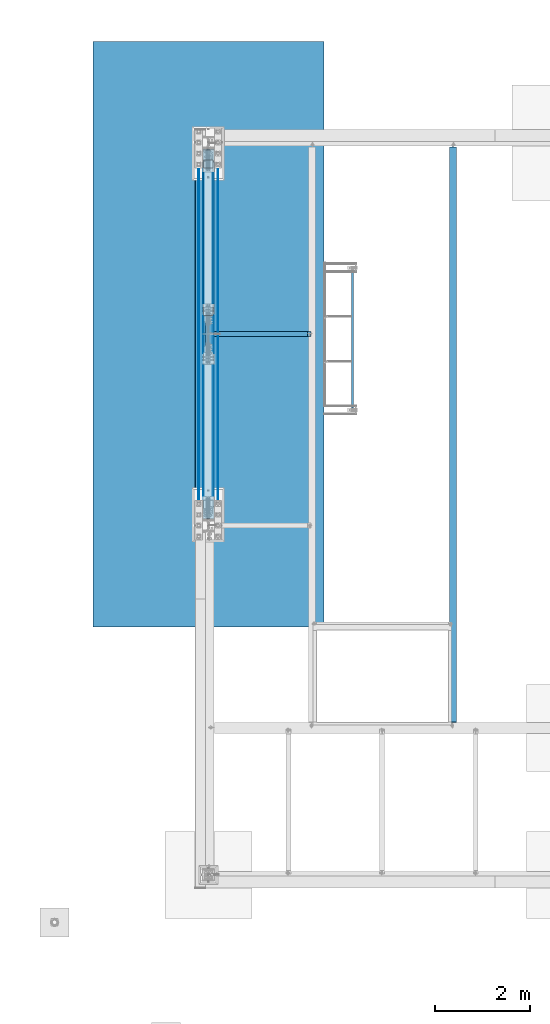
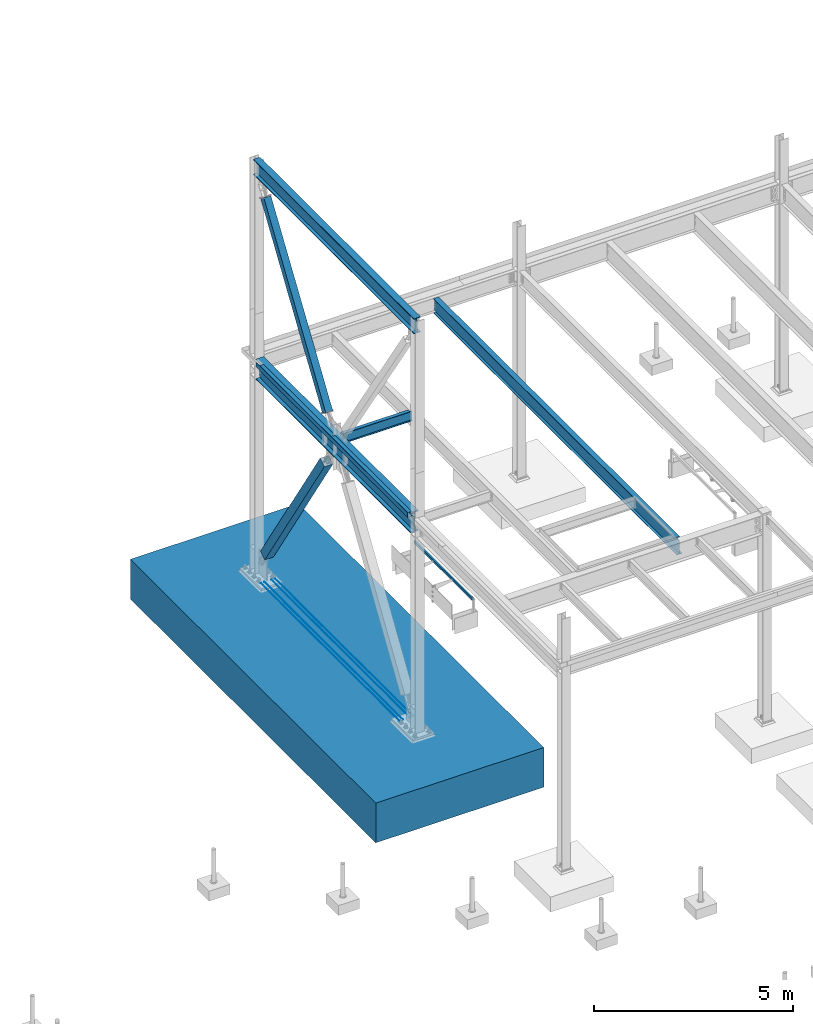
# One storey, part 1865 of 3843: 11 beams, 2 members, 12 elements without a shape of their own.
"""IFC2X3 building model written with IfcOpenShell, lengths in millimetres."""

import ifcopenshell
import ifcopenshell.guid

model = None  # the IFC model being written
_history = None  # IfcOwnerHistory: only IFC2X3 demands one
_inside = {}  # id of a spatial element -> (the spatial element, [elements in it])
_under = {}  # id of a project, library or spatial element -> (it, [spatial elements below it])
_declared = {}  # id of a project -> (the project, [libraries it declares])
_typed = {}  # id of a type object -> (the type object, [elements of that type])
_made_of = {}  # id of a material, layer set ... -> (it, [elements and type objects made of it])


def new_model(schema):
    """Start an empty IFC model of exactly this schema.

    Asked for "IFC4X3", IfcOpenShell would pick the latest addendum, in which some entities
    have other attributes; the version numbers below select the first issue.
    IFC2X3 requires an IfcOwnerHistory on every rooted entity: one is made here for all.
    """
    global model, _history
    if schema == "IFC4X3":
        model = ifcopenshell.file(schema_version=(4, 3, 0, 0))
    else:
        model = ifcopenshell.file(schema=schema)
    _inside.clear()
    _under.clear()
    _declared.clear()
    _typed.clear()
    _made_of.clear()
    _history = None
    if model.schema == "IFC2X3":
        org = make("IfcOrganization", Name="unknown")
        user = make(
            "IfcPersonAndOrganization",
            ThePerson=make("IfcPerson", FamilyName="unknown"),
            TheOrganization=org,
        )
        app = make(
            "IfcApplication",
            ApplicationDeveloper=org,
            Version="unknown",
            ApplicationFullName="unknown",
            ApplicationIdentifier="unknown",
        )
        _history = make(
            "IfcOwnerHistory",
            OwningUser=user,
            OwningApplication=app,
            ChangeAction="ADDED",
            CreationDate=0,
        )
    return model


def make(cls, **values):
    """One entity of the class cls with the attributes given. An attribute that is None is left unset."""
    return model.create_entity(
        cls, **{name: value for name, value in values.items() if value is not None}
    )


def rooted(cls, **values):
    """An entity with a GlobalId (a new one), such as an element, a storey or a relation."""
    return make(cls, GlobalId=ifcopenshell.guid.new(), OwnerHistory=_history, **values)


def si_unit(unit_type, name, prefix=None):
    """IfcSIUnit, for example si_unit("LENGTHUNIT", "METRE", prefix="MILLI")."""
    return make("IfcSIUnit", UnitType=unit_type, Prefix=prefix, Name=name)


def assignment(units):
    """IfcUnitAssignment: the units of a project."""
    return None if units is None else make("IfcUnitAssignment", Units=units)


def point(xyz):
    """IfcCartesianPoint."""
    return None if xyz is None else make("IfcCartesianPoint", Coordinates=xyz)


def direction(xyz):
    """IfcDirection."""
    return None if xyz is None else make("IfcDirection", DirectionRatios=xyz)


def frame(location, z_axis=None, x_axis=None):
    """IfcAxis2Placement3D, a coordinate frame: its origin and axes. An axis left out is left unset."""
    return make(
        "IfcAxis2Placement3D",
        Location=point(location),
        Axis=direction(z_axis),
        RefDirection=direction(x_axis),
    )


def origin_with_axes():
    """The frame at (0, 0, 0) with the z axis (0, 0, 1) and the x axis (1, 0, 0) written out."""
    return frame((0.0, 0.0, 0.0), z_axis=(0.0, 0.0, 1.0), x_axis=(1.0, 0.0, 0.0))


def place(relative_to, where):
    """IfcLocalPlacement: puts the frame where relative to a parent placement (None: the world)."""
    return make(
        "IfcLocalPlacement", PlacementRelTo=relative_to, RelativePlacement=where
    )


def context(
    kind, dimensions, precision=None, world=None, true_north=None, identifier=None
):
    """IfcGeometricRepresentationContext, for example the 3D "Model" context."""
    return make(
        "IfcGeometricRepresentationContext",
        ContextIdentifier=identifier,
        ContextType=kind,
        CoordinateSpaceDimension=dimensions,
        Precision=precision,
        WorldCoordinateSystem=world,
        TrueNorth=true_north,
    )


def subcontext(parent, identifier, kind, view, scale=None):
    """IfcGeometricRepresentationSubContext, for example "Body" below "Model"."""
    return make(
        "IfcGeometricRepresentationSubContext",
        ContextIdentifier=identifier,
        ContextType=kind,
        ParentContext=parent,
        TargetScale=scale,
        TargetView=view,
    )


def project(units=None, contexts=None):
    """IfcProject with its units and contexts."""
    return rooted(
        "IfcProject",
        Name="project",
        RepresentationContexts=contexts,
        UnitsInContext=assignment(units),
    )


def spatial(cls, under=None, at=None, **own):
    """A site, building, storey or space (cls), placed at a placement, below another one or the project."""
    s = rooted(cls, ObjectPlacement=at, **own)
    if under is not None:
        _under.setdefault(under.id(), (under, []))[1].append(s)
    return s


def faces_of(points, faces, orient=None, outer=None):
    """IfcFace entities. A face is a list of loops; a loop is a list of indices into points, from 0.

    orient and outer hold one flag for each loop. By default every Orientation is true, the
    first loop of a face is its IfcFaceOuterBound and the others are IfcFaceBound.
    """
    made = []
    for i, loops in enumerate(faces):
        bounds = []
        for j, loop in enumerate(loops):
            is_outer = j == 0 if outer is None else outer[i][j]
            bounds.append(
                make(
                    "IfcFaceOuterBound" if is_outer else "IfcFaceBound",
                    Bound=make("IfcPolyLoop", Polygon=[points[k] for k in loop]),
                    Orientation=True if orient is None else orient[i][j],
                )
            )
        made.append(make("IfcFace", Bounds=bounds))
    return made


def faceted_brep(points, faces, orient=None, outer=None, voids=None):
    """IfcFacetedBrep: a solid bounded by flat faces; with voids (closed shells), ...WithVoids."""
    shared = [point(p) for p in points]
    hull = make("IfcClosedShell", CfsFaces=faces_of(shared, faces, orient, outer))
    if voids is None:
        return make("IfcFacetedBrep", Outer=hull)
    return make(
        "IfcFacetedBrepWithVoids",
        Outer=hull,
        Voids=[
            make(cls, CfsFaces=faces_of(shared, fs, o, b)) for cls, fs, o, b in voids
        ],
    )


def shape(context_of_items, identifier, shape_type, items):
    """IfcShapeRepresentation: the items that make up one representation, for example the "Body"."""
    return make(
        "IfcShapeRepresentation",
        ContextOfItems=context_of_items,
        RepresentationIdentifier=identifier,
        RepresentationType=shape_type,
        Items=items,
    )


def material(Name=None, Category=None):
    """IfcMaterial."""
    return make("IfcMaterial", Name=Name, Category=Category)


def made_of(thing, what):
    """Note that an element or type object is made of a material, layer set ...; save() writes the relation."""
    if what is not None:
        _made_of.setdefault(what.id(), (what, []))[1].append(thing)
    return thing


def type_object(cls, material=None, **own):
    """A type object (cls), such as IfcWallType, which elements share."""
    return made_of(rooted(cls, **own), material)


def element(
    cls,
    number,
    at=None,
    inside=None,
    cuts=None,
    type_object=None,
    material=None,
    context=None,
    identifier="Body",
    shape_type=None,
    held_by="IfcProductDefinitionShape",
    body=None,
    shapes=None,
    **own,
):
    """One element of the class cls, such as IfcWall. Its Tag is "e" and its number.

    at: its placement. inside: the storey or other place that contains it. cuts: it is an
    opening in that element (IfcRelVoidsElement). A single representation is given by context,
    identifier, shape_type and body (its items); several are given by shapes. held_by: the class
    of the entity that holds the representations. save() writes the other relations.
    """
    e = rooted(cls, Tag="e%d" % number, ObjectPlacement=at, **own)
    if body is not None:
        shapes = [shape(context, identifier, shape_type, body)]
    if shapes is not None:
        e.Representation = make(held_by, Representations=shapes)
    if inside is not None:
        _inside.setdefault(inside.id(), (inside, []))[1].append(e)
    if cuts is not None:
        rooted(
            "IfcRelVoidsElement", RelatingBuildingElement=cuts, RelatedOpeningElement=e
        )
    if type_object is not None:
        _typed.setdefault(type_object.id(), (type_object, []))[1].append(e)
    return made_of(e, material)


def aggregate(whole, parts):
    """IfcRelAggregates: a whole, such as a stair, and the parts it consists of."""
    return rooted("IfcRelAggregates", RelatingObject=whole, RelatedObjects=parts)


def save(model, path):
    """Write the relations noted so far, then the file.

    IfcRelAggregates (storeys below a building ...), IfcRelContainedInSpatialStructure (elements
    in a storey), IfcRelDefinesByType, IfcRelAssociatesMaterial and IfcRelDeclares: one each for
    every whole, place, type object, material and project.
    """
    for whole, parts in _under.values():
        aggregate(whole, parts)
    for where, things in _inside.values():
        rooted(
            "IfcRelContainedInSpatialStructure",
            RelatedElements=things,
            RelatingStructure=where,
        )
    for kind, things in _typed.values():
        rooted("IfcRelDefinesByType", RelatedObjects=things, RelatingType=kind)
    for what, things in _made_of.values():
        rooted("IfcRelAssociatesMaterial", RelatedObjects=things, RelatingMaterial=what)
    for by, libraries in _declared.values():
        rooted("IfcRelDeclares", RelatingContext=by, RelatedDefinitions=libraries)
    model.write(path)


model = new_model("IFC2X3")

# Units and contexts
model_context = context("Model", 3, precision=1e-05, world=origin_with_axes())
body_context = subcontext(model_context, "Body", "Model", "MODEL_VIEW")
ifc_project = project(units=[si_unit("LENGTHUNIT", "METRE", prefix="MILLI"), si_unit("AREAUNIT", "SQUARE_METRE"), si_unit("VOLUMEUNIT", "CUBIC_METRE"), si_unit("MASSUNIT", "GRAM", prefix="KILO"), si_unit("TIMEUNIT", "SECOND"), si_unit("PLANEANGLEUNIT", "RADIAN"), si_unit("SOLIDANGLEUNIT", "STERADIAN"), si_unit("THERMODYNAMICTEMPERATUREUNIT", "DEGREE_CELSIUS"), si_unit("LUMINOUSINTENSITYUNIT", "LUMEN")], contexts=[model_context])

# Site, building, storey
site_placement = place(None, origin_with_axes())
site = spatial("IfcSite", under=ifc_project, at=site_placement, CompositionType="ELEMENT")
building_placement = place(site_placement, origin_with_axes())
building = spatial("IfcBuilding", under=site, at=building_placement, Name="Undefined", CompositionType="ELEMENT")
storey_placement = place(building_placement, origin_with_axes())
storey = spatial("IfcBuildingStorey", under=building, at=storey_placement, Name="Undefined", CompositionType="ELEMENT", Elevation=0.0)

# Assembly, beam
assembly_1_placement = place(storey_placement, origin_with_axes())
assembly_1 = element("IfcElementAssembly", 1, at=assembly_1_placement, inside=storey, Name="FRAME", AssemblyPlace="NOTDEFINED", PredefinedType="RIGID_FRAME")
ifc_material_1 = material()
beam_type_1 = type_object("IfcBeamType", Name="HSS3X2X1/4", PredefinedType="NOTDEFINED")
beam_1_placement = place(assembly_1_placement, frame((3038.078125, 98742.5, 31267.4), z_axis=(0.0, 0.0, 1.0), x_axis=(0.0, 1.0, 0.0)))
beam_1 = element("IfcBeam", 2, at=beam_1_placement, type_object=beam_type_1, material=ifc_material_1, Name="FRAME", ObjectType="HSS3X2X1/4", context=body_context, shape_type="Brep", body=[
    faceted_brep([(215.900000000001, 19.0500000000029, -31.75), (215.900000000001, -19.0500000000029, -31.75), (3136.90000000002, -19.0500000000002, -31.75), (3136.90000000002, 19.0500000000002, -31.75), (215.900000000001, -19.0500000000029, 31.75), (3136.90000000002, -19.0500000000002, 31.75), (215.900000000001, 19.0500000000029, 31.75), (3136.90000000002, 19.0500000000002, 31.75), (215.900000000001, 25.4000000000015, -38.0999999999985), (215.900000000001, 25.4000000000015, 38.0999999999985), (3136.90000000002, 25.4000000000001, 38.0999999999985), (3136.90000000002, 25.4000000000001, -38.0999999999985), (215.900000000001, -25.4000000000015, 38.0999999999985), (3136.90000000002, -25.4000000000001, 38.0999999999985), (215.900000000001, -25.4000000000015, -38.0999999999985), (3136.90000000002, -25.4000000000001, -38.0999999999985)], [[[0, 1, 2, 3]], [[1, 4, 5, 2]], [[4, 6, 7, 5]], [[6, 0, 3, 7]], [[8, 9, 10, 11]], [[9, 12, 13, 10]], [[12, 14, 15, 13]], [[14, 8, 11, 15]], [[13, 15, 11, 10], [5, 7, 3, 2]], [[14, 12, 9, 8], [6, 4, 1, 0]]]),
])
aggregate(assembly_1, [beam_1])

assembly_2_placement = place(storey_placement, origin_with_axes())
assembly_2 = element("IfcElementAssembly", 3, at=assembly_2_placement, inside=storey, Name="REBAR", AssemblyPlace="NOTDEFINED", PredefinedType="RIGID_FRAME")
ifc_material_2 = material(Name="STEEL/A706-60")
beam_type_2 = type_object("IfcBeamType", Name="#10 REBAR", PredefinedType="NOTDEFINED")
beam_2_placement = place(assembly_2_placement, frame((203.200036621129, 97040.6999682604, 29827.5375), z_axis=(0.0, 0.0, 1.0), x_axis=(0.0, 1.0, 0.0)))
beam_2 = element("IfcBeam", 4, at=beam_2_placement, type_object=beam_type_2, material=ifc_material_2, Name="REBAR", ObjectType="#10 REBAR", context=body_context, shape_type="Brep", body=[
    faceted_brep([(0.0, -7.9375, 0.0), (0.0, -5.61266007566883, -5.61266007566883), (6959.68749999408, -5.61266007566823, -5.61266007566883), (6959.68749999408, -7.9375, 0.0), (0.0, 0.0, -7.9375), (6959.68749999408, 0.0, -7.9375), (0.0, 5.61266007566883, -5.61266007566883), (6959.68749999408, 5.61266007566823, -5.61266007566883), (0.0, 7.9375, 0.0), (6959.68749999408, 7.9375, 0.0), (0.0, 5.61266007566883, 5.61266007566883), (6959.68749999408, 5.61266007566823, 5.61266007566883), (0.0, 0.0, 7.9375), (6959.68749999408, 0.0, 7.9375), (0.0, -5.61266007566883, 5.61266007566883), (6959.68749999408, -5.61266007566823, 5.61266007566883)], [[[0, 1, 2, 3]], [[1, 4, 5, 2]], [[4, 6, 7, 5]], [[6, 8, 9, 7]], [[8, 10, 11, 9]], [[10, 12, 13, 11]], [[12, 14, 15, 13]], [[14, 0, 3, 15]], [[5, 7, 9, 11, 13, 15, 3, 2]], [[14, 12, 10, 8, 6, 4, 1, 0]]]),
])
aggregate(assembly_2, [beam_2])

assembly_3_placement = place(storey_placement, origin_with_axes())
assembly_3 = element("IfcElementAssembly", 5, at=assembly_3_placement, inside=storey, Name="REBAR", AssemblyPlace="NOTDEFINED", PredefinedType="RIGID_FRAME")
beam_3_placement = place(assembly_3_placement, frame((101.600036621123, 97040.6999682604, 29827.5375), z_axis=(0.0, 0.0, 1.0), x_axis=(0.0, 1.0, 0.0)))
beam_3 = element("IfcBeam", 6, at=beam_3_placement, type_object=beam_type_2, material=ifc_material_2, Name="REBAR", ObjectType="#10 REBAR", context=body_context, shape_type="Brep", body=[
    faceted_brep([(0.0, -7.9375, 0.0), (0.0, -5.61266007566883, -5.61266007566883), (6959.68749999408, -5.61266007566823, -5.61266007566883), (6959.68749999408, -7.9375, 0.0), (0.0, 0.0, -7.9375), (6959.68749999408, 0.0, -7.9375), (0.0, 5.61266007566883, -5.61266007566883), (6959.68749999408, 5.61266007566823, -5.61266007566883), (0.0, 7.9375, 0.0), (6959.68749999408, 7.9375, 0.0), (0.0, 5.61266007566883, 5.61266007566883), (6959.68749999408, 5.61266007566823, 5.61266007566883), (0.0, 0.0, 7.9375), (6959.68749999408, 0.0, 7.9375), (0.0, -5.61266007566883, 5.61266007566883), (6959.68749999408, -5.61266007566823, 5.61266007566883)], [[[0, 1, 2, 3]], [[1, 4, 5, 2]], [[4, 6, 7, 5]], [[6, 8, 9, 7]], [[8, 10, 11, 9]], [[10, 12, 13, 11]], [[12, 14, 15, 13]], [[14, 0, 3, 15]], [[5, 7, 9, 11, 13, 15, 3, 2]], [[14, 12, 10, 8, 6, 4, 1, 0]]]),
])
aggregate(assembly_3, [beam_3])

assembly_4_placement = place(storey_placement, origin_with_axes())
assembly_4 = element("IfcElementAssembly", 7, at=assembly_4_placement, inside=storey, Name="REBAR", AssemblyPlace="NOTDEFINED", PredefinedType="RIGID_FRAME")
beam_4_placement = place(assembly_4_placement, frame((-101.599963378874, 97040.6999682604, 29827.5375), z_axis=(0.0, 0.0, 1.0), x_axis=(0.0, 1.0, 0.0)))
beam_4 = element("IfcBeam", 8, at=beam_4_placement, type_object=beam_type_2, material=ifc_material_2, Name="REBAR", ObjectType="#10 REBAR", context=body_context, shape_type="Brep", body=[
    faceted_brep([(0.0, -7.9375, 0.0), (0.0, -5.61266007566883, -5.61266007566883), (6959.68749999408, -5.61266007566823, -5.61266007566883), (6959.68749999408, -7.9375, 0.0), (0.0, 0.0, -7.9375), (6959.68749999408, 0.0, -7.9375), (0.0, 5.61266007566883, -5.61266007566883), (6959.68749999408, 5.61266007566823, -5.61266007566883), (0.0, 7.9375, 0.0), (6959.68749999408, 7.9375, 0.0), (0.0, 5.61266007566883, 5.61266007566883), (6959.68749999408, 5.61266007566823, 5.61266007566883), (0.0, 0.0, 7.9375), (6959.68749999408, 0.0, 7.9375), (0.0, -5.61266007566883, 5.61266007566883), (6959.68749999408, -5.61266007566823, 5.61266007566883)], [[[0, 1, 2, 3]], [[1, 4, 5, 2]], [[4, 6, 7, 5]], [[6, 8, 9, 7]], [[8, 10, 11, 9]], [[10, 12, 13, 11]], [[12, 14, 15, 13]], [[14, 0, 3, 15]], [[5, 7, 9, 11, 13, 15, 3, 2]], [[14, 12, 10, 8, 6, 4, 1, 0]]]),
])
aggregate(assembly_4, [beam_4])

assembly_5_placement = place(storey_placement, origin_with_axes())
assembly_5 = element("IfcElementAssembly", 9, at=assembly_5_placement, inside=storey, Name="REBAR", AssemblyPlace="NOTDEFINED", PredefinedType="RIGID_FRAME")
beam_5_placement = place(assembly_5_placement, frame((-203.19996337888, 97040.6999682604, 29827.5375), z_axis=(0.0, 0.0, 1.0), x_axis=(0.0, 1.0, 0.0)))
beam_5 = element("IfcBeam", 10, at=beam_5_placement, type_object=beam_type_2, material=ifc_material_2, Name="REBAR", ObjectType="#10 REBAR", context=body_context, shape_type="Brep", body=[
    faceted_brep([(0.0, -7.9375, 0.0), (0.0, -5.61266007566883, -5.61266007566883), (6959.68749999408, -5.61266007566823, -5.61266007566883), (6959.68749999408, -7.9375, 0.0), (0.0, 0.0, -7.9375), (6959.68749999408, 0.0, -7.9375), (0.0, 5.61266007566883, -5.61266007566883), (6959.68749999408, 5.61266007566823, -5.61266007566883), (0.0, 7.9375, 0.0), (6959.68749999408, 7.9375, 0.0), (0.0, 5.61266007566883, 5.61266007566883), (6959.68749999408, 5.61266007566823, 5.61266007566883), (0.0, 0.0, 7.9375), (6959.68749999408, 0.0, 7.9375), (0.0, -5.61266007566883, 5.61266007566883), (6959.68749999408, -5.61266007566823, 5.61266007566883)], [[[0, 1, 2, 3]], [[1, 4, 5, 2]], [[4, 6, 7, 5]], [[6, 8, 9, 7]], [[8, 10, 11, 9]], [[10, 12, 13, 11]], [[12, 14, 15, 13]], [[14, 0, 3, 15]], [[5, 7, 9, 11, 13, 15, 3, 2]], [[14, 12, 10, 8, 6, 4, 1, 0]]]),
])
aggregate(assembly_5, [beam_5])

assembly_6_placement = place(storey_placement, origin_with_axes())
assembly_6 = element("IfcElementAssembly", 11, at=assembly_6_placement, inside=storey, Name="BEAM", AssemblyPlace="NOTDEFINED", PredefinedType="RIGID_FRAME")
ifc_material_3 = material(Name="STEEL/A992")
beam_type_3 = type_object("IfcBeamType", Name="W12X19", PredefinedType="NOTDEFINED")
beam_6_placement = place(assembly_6_placement, frame((0.0, 100520.5, 36282.3125), z_axis=(0.0, 0.0, 1.0), x_axis=(1.0, 0.0, 0.0)))
beam_6 = element("IfcBeam", 12, at=beam_6_placement, type_object=beam_type_3, material=ifc_material_3, Name="BEAM", ObjectType="W12X19", context=body_context, shape_type="Brep", body=[
    faceted_brep([(2091.53125, -50.8000000000029, 153.987500000003), (2091.53125, -50.8000000000029, 144.462500000001), (2091.53125, -3.17500000000291, 144.462500000001), (2091.53125, -3.17500000000291, 141.287499809259), (2091.53125, 3.17500000000291, 141.287499809259), (2091.53125, 3.17500000000291, 144.462500000001), (2091.53125, 50.8000000000029, 144.462500000001), (2091.53125, 50.8000000000029, 153.987500000003), (2092.49797992259, -3.17500000000291, 136.427420291213), (2092.49797992259, 3.17500000000291, 136.427420291213), (2095.25099382307, -3.17500000000291, 132.307243823059), (2095.25099382307, 3.17500000000291, 132.307243823059), (2099.37117029122, -3.17500000000291, 129.554229922585), (2099.37117029122, 3.17500000000291, 129.554229922585), (2104.23124980927, -3.17500000000291, 128.587499999994), (2104.23124980927, 3.17500000000291, 128.587499999994), (2167.73125, -3.17500000000291, 128.587499999994), (2167.73125, 3.17500000000291, 128.587499999994), (134.143750000001, -50.8000000000029, 153.987500000003), (134.143750000001, 50.8000000000029, 153.987500000003), (134.143750000001, 50.8000000000029, 144.462500000001), (134.143750000001, 3.17500000000291, 144.462500000001), (134.143750000001, 3.17500000000291, 128.587499809262), (134.143750000001, -3.17500000000291, 128.587499809262), (134.143750000001, -3.17500000000291, 144.462500000001), (134.143750000001, -50.8000000000029, 144.462500000001), (133.177020077413, 3.17500000000291, 123.727420291216), (133.177020077413, -3.17500000000291, 123.727420291216), (130.424006176935, 3.17500000000291, 119.607243823062), (130.424006176935, -3.17500000000291, 119.607243823062), (126.303829708781, 3.17500000000291, 116.854229922588), (126.303829708781, -3.17500000000291, 116.854229922588), (121.443750190735, 3.17500000000291, 115.887499999997), (121.443750190735, -3.17500000000291, 115.887499999997), (19.8437500000006, 3.17500000000291, 115.887499999997), (19.8437500000006, -3.17500000000291, 115.887499999997), (19.8437500000006, 3.17500000000291, -128.587500000001), (19.8437500000006, -3.17500000000291, -128.587500000001), (121.443750190735, 3.17500000000291, -128.587500000001), (121.443750190735, -3.17500000000291, -128.587500000001), (126.303829708781, 3.17500000000291, -129.554229922593), (126.303829708781, -3.17500000000291, -129.554229922593), (130.424006176935, 3.17500000000291, -132.307243823067), (130.424006176935, -3.17500000000291, -132.307243823067), (133.177020077413, 3.17500000000291, -136.42742029122), (133.177020077413, -3.17500000000291, -136.42742029122), (134.143750000001, 3.17500000000291, -141.287499809267), (134.143750000001, -3.17500000000291, -141.287499809267), (2167.73125, 3.17500000000291, -144.462500000001), (2167.73125, 50.8000000000029, -144.462500000001), (134.143750000001, 50.8000000000029, -144.462500000001), (134.143750000001, 3.17500000000291, -144.462500000001), (2167.73125, 50.8000000000029, -153.987500000003), (134.143750000001, 50.8000000000029, -153.987500000003), (2167.73125, -50.8000000000029, -153.987500000003), (134.143750000001, -50.8000000000029, -153.987500000003), (2167.73125, -50.8000000000029, -144.462500000001), (134.143750000001, -50.8000000000029, -144.462500000001), (134.143750000001, -3.17500000000291, -144.462500000001), (2167.73125, -3.17500000000291, -144.462500000001), (2167.73125, 3.17500000000291, 115.887499999997), (2167.73125, 3.17500000000291, -114.712500000001)], [[[0, 1, 2, 3, 4, 5, 6, 7]], [[8, 9, 4, 3]], [[10, 11, 9, 8]], [[12, 13, 11, 10]], [[14, 15, 13, 12]], [[16, 17, 15, 14]], [[18, 19, 20, 21, 22, 23, 24, 25]], [[23, 22, 26, 27]], [[27, 26, 28, 29]], [[29, 28, 30, 31]], [[31, 30, 32, 33]], [[33, 32, 34, 35]], [[35, 34, 36, 37]], [[37, 36, 38, 39]], [[39, 38, 40, 41]], [[41, 40, 42, 43]], [[43, 42, 44, 45]], [[45, 44, 46, 47]], [[48, 49, 50, 51]], [[49, 52, 53, 50]], [[52, 54, 55, 53]], [[54, 56, 57, 55]], [[47, 46, 51, 50, 53, 55, 57, 58]], [[56, 59, 58, 57]], [[12, 10, 8, 3, 2, 24, 23, 27, 29, 31, 33, 35, 37, 39, 41, 43, 45, 47, 58, 59, 16, 14]], [[25, 24, 2, 1]], [[18, 25, 1, 0]], [[19, 18, 0, 7]], [[20, 19, 7, 6]], [[21, 20, 6, 5]], [[60, 61, 48, 51, 46, 44, 42, 40, 38, 36, 34, 32, 30, 28, 26, 22, 21, 5, 4, 9, 11, 13, 15, 17]], [[59, 56, 54, 52, 49, 48, 61, 60, 17, 16]]]),
])
aggregate(assembly_6, [beam_6])

# Assembly, member
assembly_7_placement = place(storey_placement, origin_with_axes())
assembly_7 = element("IfcElementAssembly", 13, at=assembly_7_placement, inside=storey, Name="None", AssemblyPlace="NOTDEFINED", PredefinedType="RIGID_FRAME")
member_type_1 = type_object("IfcMemberType", Name="HSS8X8X3/16", PredefinedType="NOTDEFINED")
member_1_placement = place(assembly_7_placement, frame((0.0, 100994.933755609, 36842.9548434273), z_axis=(1.0, 0.0, 0.0), x_axis=(0.0, 0.551394664794348, 0.834244522688839)))
member_1 = element("IfcMember", 14, at=member_1_placement, type_object=member_type_1, material=ifc_material_3, Name="None", ObjectType="HSS8X8X3/16", context=body_context, shape_type="Brep", body=[
    faceted_brep([(2.03726813197136e-10, 96.8375000003298, -96.8374999999942), (-2.18278728425503e-10, -96.837500000317, -96.8374999999942), (5645.15000007609, -96.8375000234373, -96.8375), (5645.15000007571, 96.8374999761581, -96.8375), (-2.18278728425503e-10, -96.837500000317, 96.8374999999942), (5645.15000007609, -96.8375000234373, 96.8375), (2.03726813197136e-10, 96.8375000003298, 96.8374999999942), (5645.15000007571, 96.8374999761581, 96.8375), (2.18278728425503e-10, 101.600000000345, -101.600000000006), (2.18278728425503e-10, 101.600000000345, 101.600000000006), (5645.15000007569, 101.599999976141, 101.6), (5645.15000007569, 101.599999976141, -101.6), (-2.25554686039686e-10, -101.600000000329, 101.600000000006), (5645.15000007609, -101.600000023427, 101.6), (-2.25554686039686e-10, -101.600000000329, -101.600000000006), (5645.15000007609, -101.600000023427, -101.6)], [[[0, 1, 2, 3]], [[1, 4, 5, 2]], [[4, 6, 7, 5]], [[6, 0, 3, 7]], [[8, 9, 10, 11]], [[9, 12, 13, 10]], [[12, 14, 15, 13]], [[14, 8, 11, 15]], [[13, 15, 11, 10], [5, 7, 3, 2]], [[14, 12, 9, 8], [6, 4, 1, 0]]]),
])
aggregate(assembly_7, [member_1])

# Assembly, beam
assembly_8_placement = place(storey_placement, origin_with_axes())
assembly_8 = element("IfcElementAssembly", 15, at=assembly_8_placement, inside=storey, Name="BEAM", AssemblyPlace="NOTDEFINED", PredefinedType="RIGID_FRAME")
beam_type_4 = type_object("IfcBeamType", Name="W18X65", PredefinedType="NOTDEFINED")
beam_7_placement = place(assembly_8_placement, frame((0.0, 96481.9, 42235.4375), z_axis=(0.0, 0.0, 1.0), x_axis=(0.0, 1.0, 0.0)))
beam_7 = element("IfcBeam", 16, at=beam_7_placement, type_object=beam_type_4, material=ifc_material_3, Name="BEAM", ObjectType="W18X65", context=body_context, shape_type="Brep", body=[
    faceted_brep([(0.0, 96.8374999999942, -233.362500000003), (0.0, 96.8374999999942, -214.3125), (8077.19999999998, 96.8375, -214.3125), (8077.19999999998, 96.8375, -233.362500000003), (0.0, 5.55624999999418, -214.3125), (8077.19999999998, 5.55625, -214.3125), (0.0, 5.55624999999418, 214.3125), (8077.19999999998, 5.55625, 214.3125), (0.0, 96.8374999999942, 214.3125), (8077.19999999998, 96.8375, 214.3125), (0.0, 96.8374999999942, 233.362500000003), (8077.19999999998, 96.8375, 233.362500000003), (0.0, -96.8374999999942, 233.362500000003), (8077.19999999998, -96.8375, 233.362500000003), (0.0, -96.8374999999942, 214.3125), (8077.19999999998, -96.8375, 214.3125), (0.0, -5.55624999999418, 214.3125), (8077.19999999998, -5.55625, 214.3125), (0.0, -5.55624999999418, -214.3125), (8077.19999999998, -5.55625, -214.3125), (0.0, -96.8374999999942, -214.3125), (8077.19999999998, -96.8375, -214.3125), (0.0, -96.8374999999942, -233.362500000003), (8077.19999999998, -96.8375, -233.362500000003)], [[[0, 1, 2, 3]], [[1, 4, 5, 2]], [[4, 6, 7, 5]], [[6, 8, 9, 7]], [[8, 10, 11, 9]], [[10, 12, 13, 11]], [[12, 14, 15, 13]], [[14, 16, 17, 15]], [[16, 18, 19, 17]], [[18, 20, 21, 19]], [[20, 22, 23, 21]], [[22, 0, 3, 23]], [[5, 7, 9, 11, 13, 15, 17, 19, 21, 23, 3, 2]], [[22, 20, 18, 16, 14, 12, 10, 8, 6, 4, 1, 0]]]),
])
aggregate(assembly_8, [beam_7])

# Assembly, member
assembly_9_placement = place(storey_placement, origin_with_axes())
assembly_9 = element("IfcElementAssembly", 17, at=assembly_9_placement, inside=storey, Name="None", AssemblyPlace="NOTDEFINED", PredefinedType="RIGID_FRAME")
member_type_2 = type_object("IfcMemberType", Name="HSS10X10X1/4", PredefinedType="NOTDEFINED")
member_2_placement = place(assembly_9_placement, frame((0.0, 104046.722903615, 30625.1293708069), z_axis=(1.0, 0.0, 0.0), x_axis=(0.0, -0.539727803002717, 0.841839592004237)))
member_2 = element("IfcMember", 18, at=member_2_placement, type_object=member_type_2, material=ifc_material_3, Name="None", ObjectType="HSS10X10X1/4", context=body_context, shape_type="Brep", body=[
    faceted_brep([(2.00088834390044e-10, 120.650000000089, -120.649999999994), (-2.03726813197136e-10, -120.650000000081, -120.649999999994), (5556.24999997832, -120.650000014612, -120.65), (5556.24999997871, 120.649999984533, -120.65), (-2.03726813197136e-10, -120.650000000081, 120.649999999994), (5556.24999997832, -120.650000014612, 120.65), (2.00088834390044e-10, 120.650000000089, 120.649999999994), (5556.24999997871, 120.649999984533, 120.65), (2.16459739021957e-10, 127.000000000087, -127.0), (2.16459739021957e-10, 127.000000000087, 127.0), (5556.24999997871, 126.999999984517, 127.0), (5556.24999997871, 126.999999984517, -127.0), (-2.14640749618411e-10, -127.00000000008, 127.0), (5556.2499999783, -127.000000014588, 127.0), (-2.14640749618411e-10, -127.00000000008, -127.0), (5556.2499999783, -127.000000014588, -127.0)], [[[0, 1, 2, 3]], [[1, 4, 5, 2]], [[4, 6, 7, 5]], [[6, 0, 3, 7]], [[8, 9, 10, 11]], [[9, 12, 13, 10]], [[12, 14, 15, 13]], [[14, 8, 11, 15]], [[13, 15, 11, 10], [5, 7, 3, 2]], [[14, 12, 9, 8], [6, 4, 1, 0]]]),
])
aggregate(assembly_9, [member_2])

# Assembly, beam
assembly_10_placement = place(storey_placement, origin_with_axes())
assembly_10 = element("IfcElementAssembly", 19, at=assembly_10_placement, inside=storey, Name="BEAM", AssemblyPlace="NOTDEFINED", PredefinedType="RIGID_FRAME")
ifc_material_4 = material(Name="STEEL/A36")
beam_type_5 = type_object("IfcBeamType", PredefinedType="NOTDEFINED")
beam_8_placement = place(assembly_10_placement, frame((-63.4999999994652, 100295.075, 36439.475), z_axis=(0.0, -1.0, 0.0), x_axis=(-1.0, 0.0, 0.0)))
beam_8 = element("IfcBeam", 20, at=beam_8_placement, type_object=beam_type_5, material=ifc_material_4, Name="BENT_PLATE", context=body_context, shape_type="Brep", body=[
    faceted_brep([(212.724993849368, -136.524996947686, -3810.0), (209.549993896391, -136.524996948363, -3806.825), (209.549993896348, -3.17499999999563, -3806.825), (212.724993849362, -4.76720742881298e-08, -3810.0), (0.0, -3.17500000000291, -3806.82500000006), (0.0, -7.56699591875076e-10, -3810.0), (209.550003051754, -3.17500000000291, 3810.0), (77.7875000005284, -3.17499999999563, 3810.0), (77.7875000005203, -3.17499999999563, 3633.78750000003), (2.20268248085631e-13, -3.17500000000291, 3633.78750000003), (2.20268248085631e-13, -3.17500000000291, -206.375007242459), (57.1500000005348, -3.17499999999563, -206.375007242459), (57.1500000005348, -3.17499999999563, -244.475001138941), (2.20268248085631e-13, -3.17500000000291, -244.475001138941), (57.1500000005348, 3.17500000000291, -244.475001138941), (-2.20268248085631e-13, 3.17500000000291, -244.475001138941), (57.1500000005348, 3.17500000000291, -206.375007242459), (-2.20268248085631e-13, 3.17500000000291, -206.375007242459), (209.549993897045, -136.524996947686, 3810.0), (77.7875000005203, 3.17500000000291, 3633.78750000003), (-2.20268248085631e-13, 3.17500000000291, 3633.78750000003), (77.7875000005284, 3.17500000000291, 3810.0), (215.899993897045, -136.524996947686, 3810.0), (215.89999389704, 3.17500000001746, 3810.0), (215.89999389704, 3.17500000001746, -3810.0), (215.899993897045, -136.524996947686, -3810.0), (0.0, 3.17500000000291, -3810.0)], [[[0, 1, 2, 3]], [[3, 2, 4, 5]], [[6, 7, 8, 9, 10, 11, 12, 13, 4, 2]], [[12, 14, 15, 13]], [[11, 16, 14, 12]], [[10, 17, 16, 11]], [[18, 6, 2, 1]], [[8, 19, 20, 9]], [[7, 21, 19, 8]], [[6, 18, 22, 23, 21, 7]], [[24, 23, 22, 25]], [[25, 22, 18, 1, 0]], [[26, 24, 25, 0, 3, 5]], [[13, 15, 26, 5, 4]], [[20, 19, 21, 23, 24, 26, 15, 14, 16, 17]], [[9, 20, 17, 10]]]),
])

assembly_11_placement = place(storey_placement, origin_with_axes())
assembly_11 = element("IfcElementAssembly", 21, at=assembly_11_placement, inside=storey, Name="BEAM", AssemblyPlace="NOTDEFINED", PredefinedType="RIGID_FRAME")
beam_type_6 = type_object("IfcBeamType", Name="W18X40", PredefinedType="NOTDEFINED")
beam_9_placement = place(assembly_11_placement, frame((5156.2, 92214.7, 36209.2875), z_axis=(0.0, 0.0, 1.0), x_axis=(0.0, 1.0, 0.0)))
beam_9 = element("IfcBeam", 22, at=beam_9_placement, type_object=beam_type_6, material=ifc_material_3, Name="BEAM", ObjectType="W18X40", context=body_context, shape_type="Brep", body=[
    faceted_brep([(12254.70625, -76.1999999999998, -227.012499999997), (12254.70625, 76.1999999999998, -227.012499999997), (12254.70625, 76.1999999999998, -214.57249980927), (12254.70625, -76.1999999999998, -214.57249980927), (12254.7579671776, -3.96875, -214.3125), (12254.7579671776, -76.1999999999998, -214.3125), (12254.7579671776, 76.1999999999998, -214.3125), (12254.7579671776, 3.96875, -214.3125), (12255.6729799226, 3.96875, -209.712420291224), (12255.6729799226, -3.96875, -209.712420291224), (12258.4259938231, 3.96875, -205.59224382307), (12258.4259938231, -3.96875, -205.59224382307), (12262.5461702912, 3.96875, -202.839229922596), (12262.5461702912, -3.96875, -202.839229922596), (12267.4062498093, 3.96875, -201.872500000005), (12267.4062498093, -3.96875, -201.872500000005), (12327.73125, -3.96875, -201.872500000005), (12327.73125, 3.96875, -201.872500000005), (126.206249999988, 3.96875, 214.3125), (126.206249999988, 76.1999999999998, 214.3125), (12254.70625, 76.1999999999998, 214.3125), (12254.70625, 3.96875, 214.3125), (18.2562499999767, 3.96875, 182.5625), (18.2562499999767, 3.96875, -124.237500000003), (18.2562499999767, 3.96875, -214.3125), (18.2562499999767, 76.1999999999998, -214.3125), (18.2562499999767, 76.1999999999998, -227.012499999997), (18.2562499999767, -76.1999999999998, -227.012499999997), (18.2562499999767, -76.1999999999998, -214.3125), (18.2562499999767, -3.96875, -214.3125), (18.2562499999767, -3.96875, 195.262499999997), (18.2562499999767, 3.96875, 195.262499999997), (113.506250190723, -3.96875, 195.262499999997), (113.506250190723, 3.96875, 195.262499999997), (118.366329708762, -3.96875, 196.229229922588), (118.366329708762, 3.96875, 196.229229922588), (122.486506176923, -3.96875, 198.982243823062), (122.486506176923, 3.96875, 198.982243823062), (125.239520077404, -3.96875, 203.102420291216), (125.239520077404, 3.96875, 203.102420291216), (126.206249999988, -3.96875, 207.962499809262), (126.206249999988, 3.96875, 207.962499809262), (126.206249999988, -76.1999999999998, 227.012499999997), (126.206249999988, 76.1999999999998, 227.012499999997), (126.206249999988, -3.96875, 214.3125), (126.206249999988, -76.1999999999998, 214.3125), (12254.70625, -3.96875, 214.3125), (12254.70625, -76.1999999999998, 214.3125), (12254.70625, -76.1999999999998, 227.012499999997), (12254.70625, 76.1999999999998, 227.012499999997), (12254.70625, -3.96875, 214.052499809259), (12254.70625, 3.96875, 214.052499809259), (12255.6729799226, -3.96875, 209.192420291212), (12255.6729799226, 3.96875, 209.192420291212), (12258.4259938231, -3.96875, 205.072243823059), (12258.4259938231, 3.96875, 205.072243823059), (12262.5461702912, -3.96875, 202.319229922585), (12262.5461702912, 3.96875, 202.319229922585), (12267.4062498093, -3.96875, 201.352499999994), (12267.4062498093, 3.96875, 201.352499999994), (12327.73125, -3.96875, 201.352499999994), (12327.73125, 3.96875, 201.352499999994)], [[[0, 1, 2, 3]], [[4, 5, 3, 2, 6, 7, 8, 9]], [[9, 8, 10, 11]], [[11, 10, 12, 13]], [[13, 12, 14, 15]], [[16, 15, 14, 17]], [[18, 19, 20, 21]], [[22, 23, 24, 25, 26, 27, 28, 29, 30, 31]], [[32, 33, 31, 30]], [[34, 35, 33, 32]], [[36, 37, 35, 34]], [[38, 39, 37, 36]], [[40, 41, 39, 38]], [[42, 43, 19, 18, 41, 40, 44, 45]], [[45, 44, 46, 47]], [[42, 45, 47, 48]], [[43, 42, 48, 49]], [[19, 43, 49, 20]], [[48, 47, 46, 50, 51, 21, 20, 49]], [[52, 53, 51, 50]], [[54, 55, 53, 52]], [[56, 57, 55, 54]], [[58, 59, 57, 56]], [[60, 61, 59, 58]], [[61, 60, 16, 17]], [[12, 10, 8, 7, 24, 23, 22, 31, 33, 35, 37, 39, 41, 18, 21, 51, 53, 55, 57, 59, 61, 17, 14]], [[25, 24, 7, 6]], [[1, 26, 25, 6, 2]], [[27, 26, 1, 0]], [[28, 27, 0, 3, 5]], [[29, 28, 5, 4]], [[60, 58, 56, 54, 52, 50, 46, 44, 40, 38, 36, 34, 32, 30, 29, 4, 9, 11, 13, 15, 16]]]),
])
aggregate(assembly_11, [beam_9])

# Beam
beam_type_7 = type_object("IfcBeamType", Name="W24X103", PredefinedType="NOTDEFINED")
beam_10_placement = place(assembly_10_placement, frame((0.0, 96481.9, 36125.15), z_axis=(0.0, 0.0, 1.0), x_axis=(0.0, 1.0, 0.0)))
beam_10 = element("IfcBeam", 23, at=beam_10_placement, type_object=beam_type_7, material=ifc_material_3, Name="BEAM", ObjectType="W24X103", context=body_context, shape_type="Brep", body=[
    faceted_brep([(147.94889196899, 7.1437499999343, 257.175000000003), (147.94889196899, 7.14375, -257.175000000003), (139.699999999997, -7.14375, -257.175000000003), (139.699999999997, -7.14375, 257.175000000003), (227.682368573966, -7.14375000000001, -257.175000000003), (227.682368573966, 7.14375000000001, -257.175000000003), (233.036637508223, 7.14375000000001, -258.822346293295), (233.036637508223, -7.14375000000001, -258.822346293295), (236.538867505922, 7.14375000000001, -263.194568917279), (236.538867505922, -7.14375000000001, -263.194568917279), (236.977638968936, 7.14375000000001, -268.779318261135), (236.977638968936, -7.14375000000001, -268.779318261135), (234.201181068463, 7.14375000000001, -273.644832330312), (234.201181068463, -7.14375000000001, -273.644832330312), (229.169869198537, 7.14375000000001, -276.108132250723), (229.169869198537, -7.14375000000001, -276.108132250723), (170.698000000004, 7.14375000000001, -285.353000000003), (170.698000000004, -7.14375000000001, -285.353000000003), (154.593799725801, 7.14375000000001, -285.353000000003), (154.593799725801, -7.14375, -285.353000000003), (7922.83540054839, 7.14375, -285.75), (7922.83540054839, 114.3, -285.75), (154.364599451612, 114.3, -285.75), (154.364599451612, 7.14375, -285.75), (7937.5, 114.3, -311.150000000001), (139.699999999997, 114.3, -311.150000000001), (7937.5, -114.3, -311.150000000001), (139.699999999997, -114.3, -311.150000000001), (7922.83540054839, -114.3, -285.75), (154.364599451612, -114.3, -285.75), (154.364599451612, -7.14375, -285.75), (7922.83540054839, -7.14375, -285.75), (7922.6062002742, 7.14375, -285.353000000003), (7922.6062002742, -7.14375000000001, -285.353000000003), (7906.50199999999, 7.14375, -285.353000000003), (7906.50199999999, -7.14375000000001, -285.353000000003), (7848.03013080146, 7.14375, -276.108132250723), (7848.03013080146, -7.14375000000001, -276.108132250723), (7842.99881893153, 7.14375, -273.644832330312), (7842.99881893153, -7.14375000000001, -273.644832330312), (7840.22236103106, 7.14375, -268.779318261135), (7840.22236103106, -7.14375000000001, -268.779318261135), (7840.66113249407, 7.14375, -263.194568917279), (7840.66113249407, -7.14375000000001, -263.194568917279), (7844.16336249177, 7.14375, -258.822346293295), (7844.16336249177, -7.14375000000001, -258.822346293295), (7849.51763142603, 7.14375, -257.175000000003), (7849.51763142603, -7.14375000000001, -257.175000000003), (7929.25110803101, 7.14375, -257.175000000003), (7937.5, -7.14375, -257.175000000003), (7937.5, -7.14375000005202, 257.175000000003), (7929.25110803101, 7.14375, 257.175000000003), (7848.76563142604, 7.14375000000001, 257.175000000003), (7848.76563142604, -7.14375, 257.175000000003), (7843.41136249177, 7.14375000000001, 258.822346293295), (7843.41136249177, -7.14375, 258.822346293295), (7839.90913249408, 7.14375000000001, 263.194568917279), (7839.90913249408, -7.14375, 263.194568917279), (7839.47036103107, 7.14375000000001, 268.779318261135), (7839.47036103107, -7.14375, 268.779318261135), (7842.24681893153, 7.14375000000001, 273.644832330312), (7842.24681893153, -7.14375, 273.644832330312), (7847.27813080147, 7.14375000000001, 276.108132250723), (7847.27813080147, -7.14375, 276.108132250723), (7905.75, 7.14375000000001, 285.353000000003), (7905.75, -7.14375, 285.353000000003), (7937.5, 7.14375, 285.353000000003), (7937.5, -7.14375, 285.353000000003), (7937.5, 7.14375, 285.75), (7937.5, -7.14375, 285.75), (7937.5, -114.3, 285.75), (7937.5, 114.3, 285.75), (7922.83541279065, 114.3, 311.150000000001), (7922.83541279065, -114.3, 311.150000000001), (139.699999999997, 7.14375, 285.75), (139.699999999997, 114.3, 285.75), (154.364587209348, 114.3, 311.150000000001), (154.364587209348, -114.3, 311.150000000001), (139.699999999997, -114.3, 285.75), (139.699999999997, -7.14375, 285.75), (139.699999999997, 7.14375, 285.353000000003), (139.699999999997, -7.14375, 285.353000000003), (171.449999999997, 7.14375000000001, 285.353000000003), (171.449999999997, -7.14375000000001, 285.353000000003), (229.92186919853, 7.14375000000001, 276.108132250723), (229.92186919853, -7.14375000000001, 276.108132250723), (234.953181068457, 7.14375000000001, 273.644832330312), (234.953181068457, -7.14375000000001, 273.644832330312), (237.729638968929, 7.14375000000001, 268.779318261135), (237.729638968929, -7.14375000000001, 268.779318261135), (237.290867505915, 7.14375000000001, 263.194568917279), (237.290867505915, -7.14375000000001, 263.194568917279), (233.788637508231, 7.14375000000001, 258.822346293295), (233.788637508231, -7.14375000000001, 258.822346293295), (228.434368573959, 7.14375000000001, 257.175000000003), (228.434368573959, -7.14375000000001, 257.175000000003)], [[[0, 1, 2, 3]], [[4, 5, 6, 7]], [[7, 6, 8, 9]], [[9, 8, 10, 11]], [[11, 10, 12, 13]], [[13, 12, 14, 15]], [[15, 14, 16, 17]], [[17, 16, 18, 19]], [[20, 21, 22, 23]], [[21, 24, 25, 22]], [[24, 26, 27, 25]], [[26, 28, 29, 27]], [[19, 18, 23, 22, 25, 27, 29, 30]], [[28, 31, 30, 29]], [[26, 24, 21, 20, 32, 33, 31, 28]], [[34, 35, 33, 32]], [[35, 34, 36, 37]], [[37, 36, 38, 39]], [[39, 38, 40, 41]], [[41, 40, 42, 43]], [[43, 42, 44, 45]], [[45, 44, 46, 47]], [[47, 46, 48, 49]], [[50, 49, 48, 51]], [[52, 53, 50, 51]], [[53, 52, 54, 55]], [[55, 54, 56, 57]], [[57, 56, 58, 59]], [[59, 58, 60, 61]], [[61, 60, 62, 63]], [[63, 62, 64, 65]], [[65, 64, 66, 67]], [[67, 66, 68, 69]], [[70, 69, 68, 71, 72, 73]], [[71, 68, 74, 75]], [[72, 71, 75, 76]], [[73, 72, 76, 77]], [[70, 73, 77, 78]], [[69, 70, 78, 79]], [[77, 76, 75, 74, 79, 78]], [[80, 81, 79, 74]], [[82, 83, 81, 80]], [[83, 82, 84, 85]], [[85, 84, 86, 87]], [[87, 86, 88, 89]], [[89, 88, 90, 91]], [[91, 90, 92, 93]], [[93, 92, 94, 95]], [[95, 94, 0, 3]], [[4, 7, 9, 11, 13, 15, 17, 19, 30, 31, 33, 35, 37, 39, 41, 43, 45, 47, 49, 50, 53, 55, 57, 59, 61, 63, 65, 67, 69, 79, 81, 83, 85, 87, 89, 91, 93, 95, 3, 2]], [[5, 4, 2, 1]], [[94, 92, 90, 88, 86, 84, 82, 80, 74, 68, 66, 64, 62, 60, 58, 56, 54, 52, 51, 48, 46, 44, 42, 40, 38, 36, 34, 32, 20, 23, 18, 16, 14, 12, 10, 8, 6, 5, 1, 0]]]),
])

aggregate(assembly_10, [beam_8, beam_10])

# Assembly, beam
assembly_12_placement = place(storey_placement, origin_with_axes())
assembly_12 = element("IfcElementAssembly", 24, at=assembly_12_placement, inside=storey, Name="BEAM", AssemblyPlace="NOTDEFINED", PredefinedType="REINFORCEMENT_UNIT")
ifc_material_5 = material(Name="CONCRETE/5000")
beam_type_8 = type_object("IfcBeamType", PredefinedType="NOTDEFINED")
beam_11_placement = place(assembly_12_placement, frame((-6.82121026329696e-13, 94348.3, 29108.4), z_axis=(0.0, 0.0, 1.0), x_axis=(0.0, 1.0, 0.0)))
beam_11 = element("IfcBeam", 25, at=beam_11_placement, type_object=beam_type_8, material=ifc_material_5, Name="BEAM", context=body_context, shape_type="Brep", body=[
    faceted_brep([(0.0, 2438.4, -609.599999999999), (0.0, 2438.4, 609.599999999999), (12344.4, 2438.4, 609.599999999999), (12344.4, 2438.4, -609.599999999999), (0.0, -2438.4, 609.599999999999), (12344.4, -2438.4, 609.599999999999), (0.0, -2438.4, -609.599999999999), (12344.4, -2438.4, -609.599999999999)], [[[0, 1, 2, 3]], [[1, 4, 5, 2]], [[4, 6, 7, 5]], [[6, 0, 3, 7]], [[5, 7, 3, 2]], [[6, 4, 1, 0]]]),
])
aggregate(assembly_12, [beam_11])

save(model, "model.ifc")
